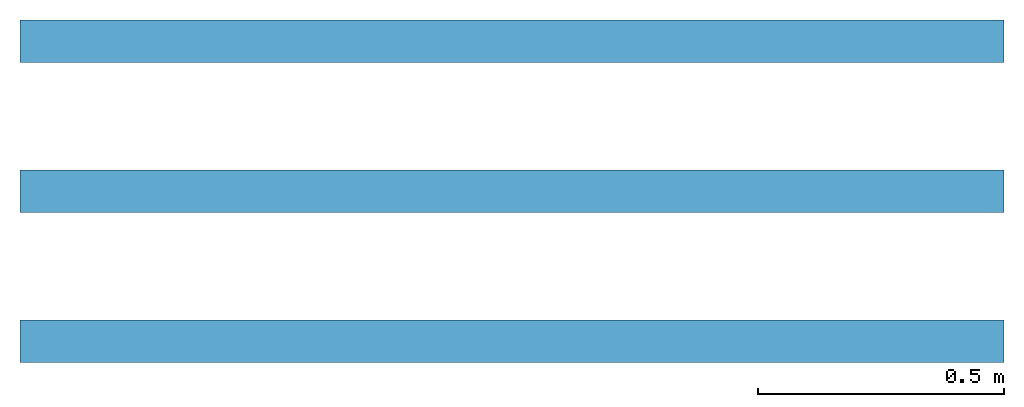
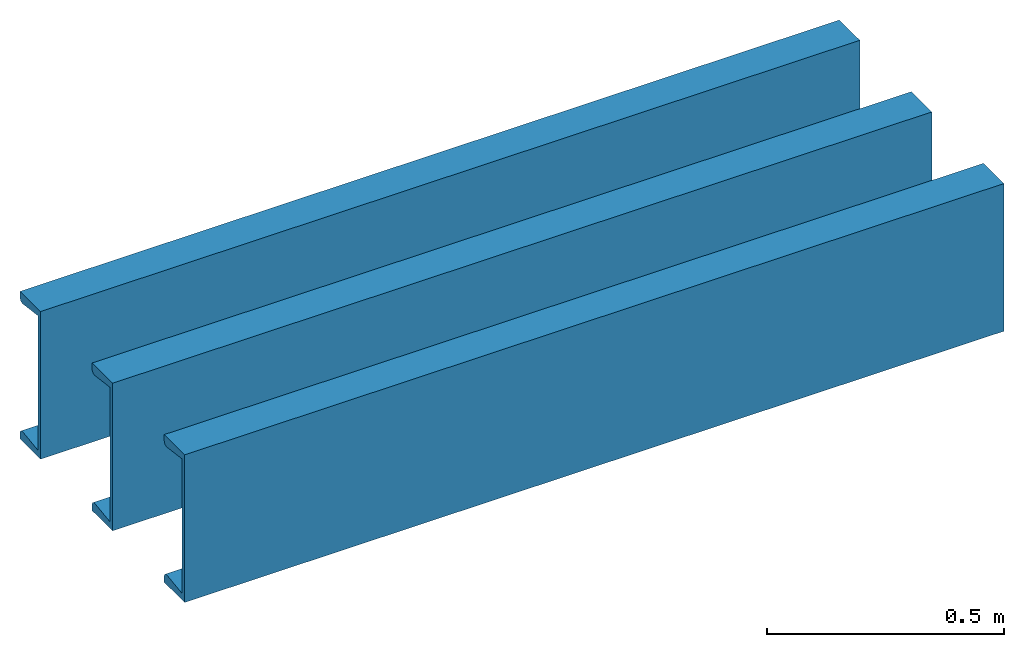
# One storey: 3 beams.
"""IFC4 building model written with IfcOpenShell, lengths in inches."""

from ifc_helpers import new_model, entity, si_unit, converted_unit, frame, frame_2d, origin_with_axes, place, context, subcontext, project, spatial, u_section, extrude, material, material_profile, profile_set, profile_usage, type_object, element, save


model = new_model("IFC4")

# Units and contexts
model_context = context("Model", 3, precision=1e-05, world=origin_with_axes())
plan_context = context("Plan", 2, precision=1e-05, world=frame_2d((0.0, 0.0, 0.0), x_axis=(1.0, 0.0, 0.0)))
body_context = subcontext(model_context, "Body", "Model", "MODEL_VIEW")
ifc_project = project(units=[converted_unit("VOLUMEUNIT", "cubic inch", entity("IfcReal", 1.639e-05), si_unit("VOLUMEUNIT", "CUBIC_METRE"), dimensions=[3, 0, 0, 0, 0, 0, 0]), converted_unit("AREAUNIT", "square inch", entity("IfcReal", 0.0006452), si_unit("AREAUNIT", "SQUARE_METRE"), dimensions=[2, 0, 0, 0, 0, 0, 0]), converted_unit("LENGTHUNIT", "inch", entity("IfcReal", 0.0254), si_unit("LENGTHUNIT", "METRE"), dimensions=[1, 0, 0, 0, 0, 0, 0])], contexts=[model_context, plan_context])

# Site, building, storey
site_placement = place(None, origin_with_axes())
site = spatial("IfcSite", under=ifc_project, at=site_placement)
building_placement = place(site_placement, origin_with_axes())
building = spatial("IfcBuilding", under=site, at=building_placement, Name="Building")
storey_placement = place(building_placement, origin_with_axes())
storey = spatial("IfcBuildingStorey", under=building, at=storey_placement, Name="Storey")

# Beams
ifc_material = material(Name="C STEEL BEAM 1 MAT")
ifc_material_profile = material_profile(ifc_material, u_section(Depth=15.0, FlangeWidth=3.40000009536743, WebThickness=0.400000005960464, FlangeThickness=0.836000025272369, FilletRadius=0.0, EdgeRadius=0.409999996423721, FlangeSlope=15.8380002975464), Name="C STEEL BEAM 1")
ifc_profile_set = profile_set([ifc_material_profile], Name="C STEEL BEAM 1")
ifc_profile_usage_1 = profile_usage(ifc_profile_set)
beam_type = type_object("IfcBeamType", Name="C STEEL BEAM 1", PredefinedType="BEAM", material=ifc_profile_set)
beam_1_placement = place(storey_placement, frame((0.0, 0.0, 0.0), z_axis=(1.0, 4.37113882867379e-08, -4.37113882867379e-08), x_axis=(-4.37113882867379e-08, 1.0, 0.0)))
element("IfcBeam", 1, at=beam_1_placement, inside=storey, type_object=beam_type, material=ifc_profile_usage_1, Name="Beam", context=body_context, shape_type="SweptSolid", body=[
    extrude(u_section(Depth=15.0, FlangeWidth=3.40000009536743, WebThickness=0.400000005960464, FlangeThickness=0.836000025272369, FilletRadius=0.0, EdgeRadius=0.409999996423721, FlangeSlope=15.8380002975464), None, (0.0, 0.0, 1.0), 78.740157480315),
])
ifc_profile_usage_2 = profile_usage(ifc_profile_set)
beam_2_placement = place(storey_placement, frame((-5.24536669567488e-07, 12.0000001483076, 0.0), z_axis=(1.0, 4.37113882867379e-08, -4.37113882867379e-08), x_axis=(-4.37113882867379e-08, 1.0, 0.0)))
element("IfcBeam", 2, at=beam_2_placement, inside=storey, type_object=beam_type, material=ifc_profile_usage_2, Name="Beam", context=body_context, shape_type="SweptSolid", body=[
    extrude(u_section(Depth=15.0, FlangeWidth=3.40000009536743, WebThickness=0.400000005960464, FlangeThickness=0.836000025272369, FilletRadius=0.0, EdgeRadius=0.409999996423721, FlangeSlope=15.8380002975464), None, (0.0, 0.0, 1.0), 78.740157480315),
])
ifc_profile_usage_3 = profile_usage(ifc_profile_set)
beam_3_placement = place(storey_placement, frame((-1.04907333913498e-06, 24.0000002966152, 0.0), z_axis=(1.0, 4.37113882867379e-08, -4.37113882867379e-08), x_axis=(-4.37113882867379e-08, 1.0, 0.0)))
element("IfcBeam", 3, at=beam_3_placement, inside=storey, type_object=beam_type, material=ifc_profile_usage_3, Name="Beam", context=body_context, shape_type="SweptSolid", body=[
    extrude(u_section(Depth=15.0, FlangeWidth=3.40000009536743, WebThickness=0.400000005960464, FlangeThickness=0.836000025272369, FilletRadius=0.0, EdgeRadius=0.409999996423721, FlangeSlope=15.8380002975464), None, (0.0, 0.0, 1.0), 78.740157480315),
])

save(model, "model.ifc")
